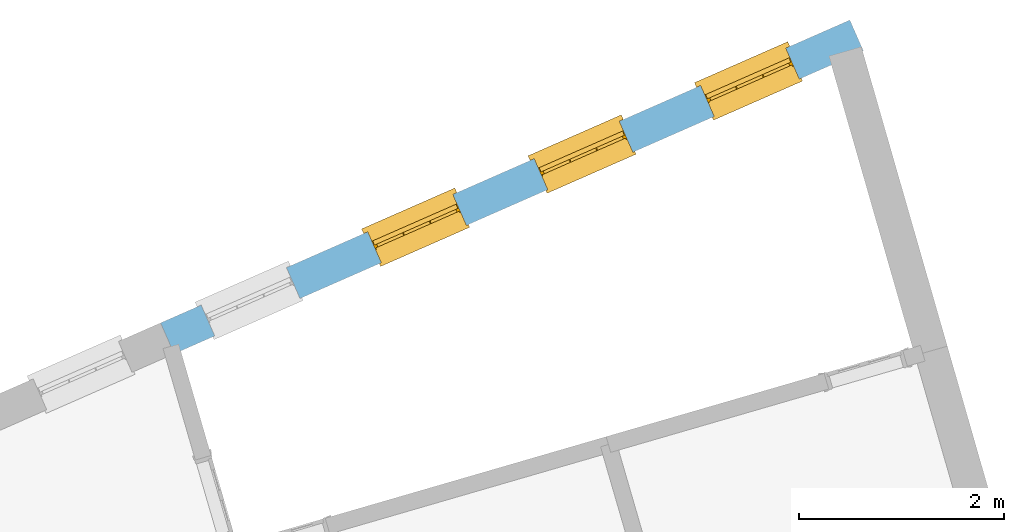
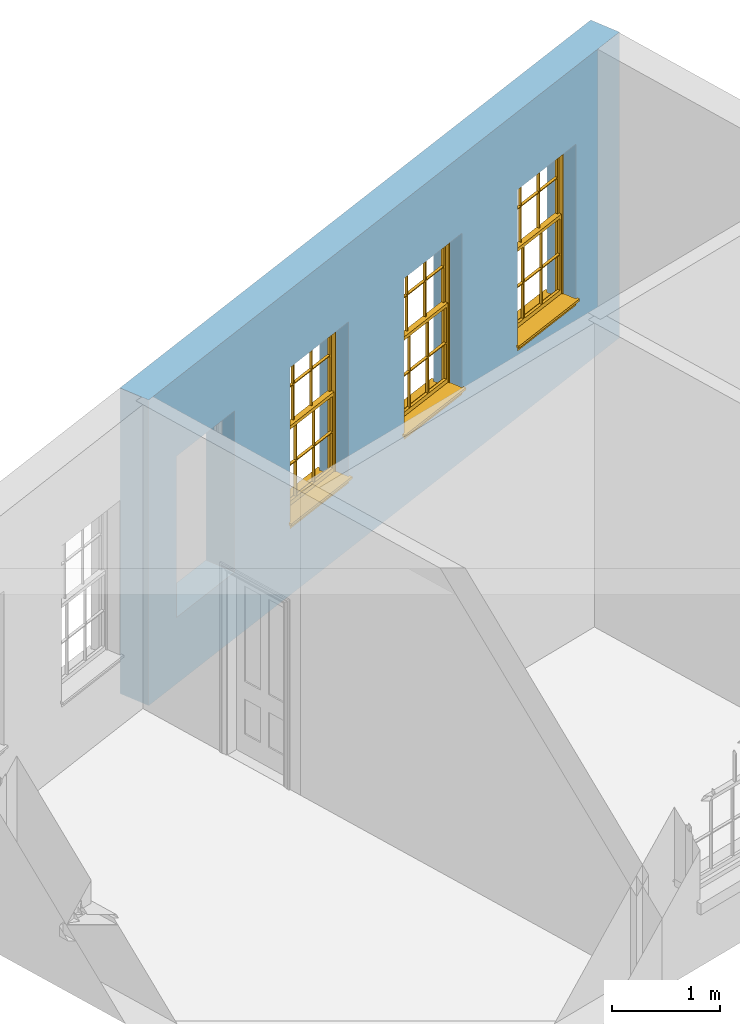
# One storey, part 8 of 11: 3 windows, 4 openings, plus 1 element that does not belong to this part.
"""IFC2X3 building model written with IfcOpenShell, lengths in metres."""

from ifc_helpers import new_model, si_unit, frame, origin, place, context, subcontext, project, spatial, polyline, outline, extrude, faceted_brep, material, layer, layer_set, layer_usage, element, fill, save


model = new_model("IFC2X3")

# Units and contexts
model_context = context("Model", 3, world=origin())
body_context = subcontext(model_context, "Body", "Model", "MODEL_VIEW")
ifc_project = project(units=[si_unit("PLANEANGLEUNIT", "RADIAN"), si_unit("MASSUNIT", "GRAM", prefix="KILO"), si_unit("FORCEUNIT", "NEWTON", prefix="KILO"), si_unit("LENGTHUNIT", "METRE")], contexts=[model_context])

# Site, building, storey
site_placement = place(None, origin())
site = spatial("IfcSite", under=ifc_project, at=site_placement, CompositionType="ELEMENT")
building_placement = place(None, origin())
building = spatial("IfcBuilding", under=site, at=building_placement, Name="Building plot-15", CompositionType="ELEMENT")
storey_placement = place(None, frame((0.0, 0.0, 7.6)))
storey = spatial("IfcBuildingStorey", under=building, at=storey_placement, Name="Floor 1", CompositionType="ELEMENT", Elevation=7.6)

# Wall, openings, windows
ifc_material = material(Name="Masonry")
ifc_layer = layer(ifc_material, 0.33, ventilated=False)
ifc_layer_set = layer_set([ifc_layer], Name="My Wall")
ifc_layer_usage = layer_usage(ifc_layer_set, "AXIS2", "NEGATIVE", 0.08)
wall_placement = place(storey_placement, origin())
wall = element("IfcWallStandardCase", 1, at=wall_placement, inside=storey, material=ifc_layer_usage, Name="exterior", context=body_context, shape_type="SweptSolid", body=[
    extrude(outline(polyline([(95.6723187451732, 60.4106615143609), (95.5395561949644, 60.7127775603797), (88.804220166514, 57.7529864488727), (88.9369827167228, 57.4508704028539), (95.6723187451732, 60.4106615143609)])), origin(), (0.0, 0.0, 1.0), 3.45),
])
opening_1_placement = place(storey_placement, frame((0.0, 0.0, 0.75)))
opening_1 = element("IfcOpeningElement", 2, at=opening_1_placement, cuts=wall, Name="Opening", ObjectType="Opening", context=body_context, shape_type="SweptSolid", body=[
    extrude(outline(polyline([(94.9139268152625, 60.4378495880681), (94.0808189307863, 60.0717467980984), (94.2135814809951, 59.7696307520796), (95.0466893654713, 60.1357335420493), (94.9139268152625, 60.4378495880681)])), origin(), (0.0, 0.0, 1.0), 1.82),
])
opening_2_placement = place(storey_placement, frame((0.0, 0.0, 0.75)))
opening_2 = element("IfcOpeningElement", 3, at=opening_2_placement, cuts=wall, Name="Opening", ObjectType="Opening", context=body_context, shape_type="SweptSolid", body=[
    extrude(outline(polyline([(93.2873117562595, 59.7230462325794), (92.4542038717833, 59.3569434426097), (92.5869664219921, 59.0548273965908), (93.4200743064683, 59.4209301865605), (93.2873117562595, 59.7230462325794)])), origin(), (0.0, 0.0, 1.0), 1.82),
])
opening_3_placement = place(storey_placement, frame((0.0, 0.0, 0.75)))
opening_3 = element("IfcOpeningElement", 4, at=opening_3_placement, cuts=wall, Name="Opening", ObjectType="Opening", context=body_context, shape_type="SweptSolid", body=[
    extrude(outline(polyline([(91.6606966972566, 59.0082428770907), (90.8275888127803, 58.642140087121), (90.9603513629891, 58.3400240411021), (91.7934592474653, 58.7061268310718), (91.6606966972566, 59.0082428770907)])), origin(), (0.0, 0.0, 1.0), 1.82),
])
opening_4_placement = place(storey_placement, frame((0.0, 0.0, 0.75)))
element("IfcOpeningElement", 5, at=opening_4_placement, cuts=wall, Name="Opening", ObjectType="Opening", context=body_context, shape_type="SweptSolid", body=[
    extrude(outline(polyline([(90.0340816382536, 58.2934395216019), (89.2009737537774, 57.9273367316322), (89.3337363039862, 57.6252206856134), (90.1668441884623, 57.9913234755831), (90.0340816382536, 58.2934395216019)])), origin(), (0.0, 0.0, 1.0), 1.82),
])
window_1_placement = place(storey_placement, frame((95.0145045048146, 60.2089737956296, 0.75), z_axis=(0.0, 0.0, 1.0), x_axis=(-0.833107884476192, -0.366102789969688, 0.0)))
window_1 = element("IfcWindow", 6, at=window_1_placement, inside=storey, Name="circulation outside window", OverallHeight=1.82, OverallWidth=0.91, context=body_context, shape_type="Brep", held_by="IfcProductRepresentation", body=[
    faceted_brep([(0.033125, -0.105, 0.975209), (0.01, -0.105, 0.975209), (0.033125, -0.105, 1.376042), (0.876875, -0.105, 0.975209), (0.876875, -0.105, 1.376042), (0.9, -0.105, 0.975209), (0.876875, -0.105, 1.386042), (0.876875, -0.105, 1.786875), (0.9, -0.105, 1.81), (0.033125, -0.105, 1.786875), (0.033125, -0.105, 1.386042), (0.01, -0.105, 1.81), (0.876875, -0.135, 1.376042), (0.876875, -0.135, 0.975209), (0.9, -0.135, 0.937083), (0.033125, -0.135, 1.786875), (0.01, -0.135, 1.81), (0.033125, -0.135, 1.386042), (0.01, -0.135, 0.937083), (0.033125, -0.135, 0.975209), (0.033125, -0.135, 1.376042), (0.876875, -0.135, 1.786875), (0.876875, -0.135, 1.386042), (0.9, -0.135, 1.81), (0.033125, -0.105, 0.937083), (0.01, -0.105, 0.937083), (0.033125, -0.105, 0.53625), (0.876875, -0.105, 0.937083), (0.876875, -0.105, 0.53625), (0.9, -0.105, 0.937083), (0.876875, -0.105, 0.52625), (0.876875, -0.105, 0.125417), (0.9, -0.105, 0.077167), (0.033125, -0.105, 0.125417), (0.033125, -0.105, 0.52625), (0.01, -0.105, 0.077167), (-0.0425, -0.25, 0.01), (-0.0425, -0.3, 0.001667), (0.0, -0.25, 0.01), (0.9525, -0.25, 0.01), (0.91, -0.25, 0.01), (0.9525, -0.3, 0.001667), (-0.02, 0.08, 0.077167), (0.0, 0.08, 0.077167), (-0.02, 0.11, 0.077167), (0.0, -0.06, 0.077167), (0.01, -0.06, 0.077167), (0.91, -0.06, 0.077167), (0.91, 0.08, 0.077167), (0.9, -0.06, 0.077167), (0.93, 0.08, 0.077167), (0.93, 0.11, 0.077167), (0.01, -0.075, 0.975209), (0.9, -0.075, 0.975209), (0.876875, -0.075, 0.125417), (0.876875, -0.075, 0.52625), (0.9, -0.075, 0.077167), (0.876875, -0.075, 0.53625), (0.876875, -0.075, 0.937083), (0.033125, -0.075, 0.125417), (0.01, -0.075, 0.077167), (0.033125, -0.075, 0.52625), (0.033125, -0.075, 0.937083), (0.033125, -0.075, 0.53625), (-0.02, 0.08, 0.052167), (-0.02, 0.11, 0.052167), (0.93, 0.11, 0.052167), (0.93, 0.08, 0.052167), (0.91, 0.08, 0.052167), (0.0, 0.08, 0.052167), (0.91, -0.15, 0.026667), (0.0, -0.15, 0.026667), (-0.0425, -0.3, -0.123333), (0.9525, -0.3, -0.123333), (-0.0425, -0.25, -0.123333), (0.9525, -0.25, -0.123333), (0.01, -0.06, 1.81), (0.9, -0.06, 1.81), (0.0, -0.06, 1.82), (0.91, -0.06, 1.82), (0.01, -0.15, 0.077167), (0.9, -0.15, 0.077167), (0.592292, -0.105, 0.125417), (0.592292, -0.075, 0.125417), (0.317708, -0.075, 0.125417), (0.317708, -0.105, 0.125417), (0.592292, -0.105, 0.53625), (0.317708, -0.105, 0.53625), (0.317708, -0.105, 0.52625), (0.592292, -0.105, 0.52625), (0.592292, -0.075, 0.53625), (0.317708, -0.075, 0.53625), (0.592292, -0.135, 1.386042), (0.592292, -0.105, 1.386042), (0.317708, -0.105, 1.386042), (0.317708, -0.135, 1.386042), (0.317708, -0.135, 1.376042), (0.592292, -0.135, 1.376042), (0.317708, -0.105, 1.376042), (0.592292, -0.105, 1.376042), (0.602292, -0.135, 1.376042), (0.592292, -0.135, 0.975209), (0.602292, -0.135, 0.975209), (0.602292, -0.105, 0.975209), (0.592292, -0.105, 0.975209), (0.602292, -0.105, 1.376042), (0.602292, -0.075, 0.53625), (0.602292, -0.105, 0.53625), (0.317708, -0.075, 0.52625), (0.307708, -0.075, 0.125417), (0.307708, -0.075, 0.52625), (0.602292, -0.075, 0.52625), (0.602292, -0.075, 0.125417), (0.592292, -0.075, 0.52625), (0.307708, -0.075, 0.53625), (0.317708, -0.075, 0.937083), (0.307708, -0.075, 0.937083), (0.602292, -0.075, 0.937083), (0.592292, -0.075, 0.937083), (0.307708, -0.105, 0.52625), (0.307708, -0.105, 0.125417), (0.307708, -0.105, 0.53625), (0.307708, -0.105, 0.937083), (0.592292, -0.105, 0.937083), (0.317708, -0.105, 0.937083), (0.602292, -0.105, 0.937083), (0.602292, -0.105, 0.52625), (0.602292, -0.105, 0.125417), (0.307708, -0.135, 1.386042), (0.307708, -0.135, 1.376042), (0.307708, -0.135, 0.975209), (0.317708, -0.135, 0.975209), (0.317708, -0.135, 1.786875), (0.307708, -0.135, 1.786875), (0.602292, -0.135, 1.786875), (0.592292, -0.135, 1.786875), (0.602292, -0.135, 1.386042), (0.602292, -0.105, 1.386042), (0.307708, -0.105, 1.386042), (0.307708, -0.105, 1.786875), (0.317708, -0.105, 1.786875), (0.592292, -0.105, 1.786875), (0.602292, -0.105, 1.786875), (0.307708, -0.105, 1.376042), (0.317708, -0.105, 0.975209), (0.307708, -0.105, 0.975209), (0.91, -0.15, 1.82), (0.9, -0.15, 1.81), (0.01, -0.15, 1.81), (0.0, -0.15, 1.82), (0.91, -0.25, 0.0), (0.0, -0.25, 0.0), (0.91, 0.08, 0.0), (0.0, 0.08, 0.0)], [[[0, 1, 2]], [[3, 4, 5]], [[6, 7, 8]], [[9, 10, 11]], [[12, 13, 14]], [[15, 16, 17]], [[18, 19, 20]], [[21, 22, 23]], [[24, 25, 26]], [[27, 28, 29]], [[30, 31, 32]], [[33, 34, 35]], [[14, 27, 29]], [[25, 24, 18]], [[36, 37, 38]], [[39, 40, 41]], [[42, 43, 44]], [[45, 46, 43]], [[47, 48, 49]], [[50, 51, 48]], [[1, 0, 52]], [[5, 53, 3]], [[54, 55, 56]], [[57, 58, 53]], [[59, 60, 61]], [[62, 63, 52]], [[48, 43, 46, 49]], [[51, 44, 43, 48]], [[64, 42, 44, 65]], [[65, 44, 51, 66]], [[66, 51, 50, 67]], [[65, 66, 68, 69]], [[60, 56, 49, 46]], [[70, 71, 38, 40]], [[37, 41, 40, 38]], [[37, 72, 73, 41]], [[74, 75, 73, 72]], [[8, 11, 76, 77]], [[76, 78, 79, 77]], [[32, 35, 80, 81]], [[81, 80, 71, 70]], [[82, 83, 84, 85]], [[86, 87, 88, 89]], [[86, 90, 91, 87]], [[92, 93, 94, 95]], [[92, 95, 96, 97]], [[96, 98, 99, 97]], [[100, 97, 101, 102]], [[103, 104, 99, 105]], [[97, 99, 104, 101]], [[102, 103, 105, 100]], [[28, 57, 106, 107]], [[108, 84, 109, 110]], [[111, 112, 83, 113]], [[114, 110, 61, 63]], [[90, 113, 108, 91]], [[115, 91, 114, 116]], [[117, 106, 90, 118]], [[111, 106, 57, 55]], [[119, 110, 109, 120]], [[34, 61, 110, 119]], [[89, 113, 83, 82]], [[88, 108, 113, 89]], [[85, 84, 108, 88]], [[121, 114, 63, 26]], [[122, 116, 114, 121]], [[123, 118, 90, 86]], [[87, 91, 115, 124]], [[107, 106, 117, 125]], [[126, 111, 55, 30]], [[127, 112, 111, 126]], [[126, 30, 28, 107]], [[88, 119, 120, 85]], [[126, 89, 82, 127]], [[125, 123, 86, 107]], [[121, 26, 34, 119]], [[124, 122, 121, 87]], [[128, 17, 20, 129]], [[96, 129, 130, 131]], [[132, 133, 128, 95]], [[134, 135, 92, 136]], [[100, 12, 22, 136]], [[137, 6, 4, 105]], [[94, 138, 139, 140]], [[137, 93, 141, 142]], [[99, 98, 94, 93]], [[143, 2, 10, 138]], [[144, 145, 143, 98]], [[129, 143, 145, 130]], [[20, 2, 143, 129]], [[131, 144, 98, 96]], [[128, 138, 10, 17]], [[133, 139, 138, 128]], [[135, 141, 93, 92]], [[95, 94, 140, 132]], [[22, 6, 137, 136]], [[136, 137, 142, 134]], [[100, 105, 4, 12]], [[107, 86, 89, 126]], [[106, 111, 113, 90]], [[91, 108, 110, 114]], [[87, 121, 119, 88]], [[97, 100, 136, 92]], [[129, 96, 95, 128]], [[98, 143, 138, 94]], [[105, 99, 93, 137]], [[131, 101, 104, 144]], [[124, 115, 118, 123]], [[132, 140, 141, 135]], [[120, 109, 59, 33]], [[15, 9, 139, 133]], [[134, 142, 7, 21]], [[31, 54, 112, 127]], [[36, 74, 72, 37]], [[39, 41, 73, 75]], [[18, 14, 101, 131]], [[23, 16, 132, 135]], [[83, 56, 60, 84]], [[52, 53, 118, 115]], [[53, 52, 144, 104]], [[11, 8, 141, 140]], [[14, 18, 124, 123]], [[2, 1, 11, 10]], [[8, 5, 4, 6]], [[57, 53, 56, 55]], [[60, 52, 63, 61]], [[26, 25, 35, 34]], [[32, 29, 28, 30]], [[14, 23, 22, 12]], [[18, 20, 17, 16]], [[19, 0, 2, 20]], [[17, 10, 9, 15]], [[12, 4, 3, 13]], [[21, 7, 6, 22]], [[27, 58, 57, 28]], [[30, 55, 54, 31]], [[33, 59, 61, 34]], [[26, 63, 62, 24]], [[5, 8, 77, 53]], [[76, 11, 1, 52]], [[46, 45, 78, 76]], [[49, 77, 79, 47]], [[70, 146, 147, 81]], [[71, 80, 148, 149]], [[19, 130, 145, 0]], [[102, 13, 3, 103]], [[116, 122, 24, 62]], [[29, 32, 81, 14]], [[80, 35, 25, 18]], [[60, 46, 76, 52]], [[77, 49, 56, 53]], [[23, 14, 81, 147]], [[16, 148, 80, 18]], [[35, 85, 120]], [[120, 33, 35]], [[127, 82, 32]], [[32, 31, 127]], [[32, 82, 85, 35]], [[102, 101, 14]], [[14, 13, 102]], [[18, 131, 130]], [[130, 19, 18]], [[134, 21, 23]], [[23, 135, 134]], [[16, 15, 133]], [[133, 132, 16]], [[11, 140, 139]], [[139, 9, 11]], [[142, 141, 8]], [[8, 7, 142]], [[23, 147, 148, 16]], [[146, 149, 148, 147]], [[52, 115, 116]], [[116, 62, 52]], [[118, 53, 117]], [[58, 117, 53]], [[27, 125, 117, 58]], [[56, 83, 112]], [[112, 54, 56]], [[109, 84, 60]], [[60, 59, 109]], [[125, 27, 14]], [[14, 123, 125]], [[122, 124, 18]], [[18, 24, 122]], [[145, 144, 52]], [[52, 0, 145]], [[103, 3, 53]], [[53, 104, 103]], [[79, 78, 149, 146]], [[78, 45, 71, 149]], [[146, 70, 47, 79]], [[150, 75, 74, 151]], [[68, 66, 67]], [[48, 68, 67, 50]], [[69, 64, 65]], [[42, 64, 69, 43]], [[69, 68, 152, 153]], [[70, 68, 48, 47]], [[150, 152, 68, 70]], [[43, 69, 71, 45]], [[69, 153, 151, 71]], [[152, 150, 151, 153]], [[38, 151, 74, 36]], [[71, 151, 38]], [[39, 75, 150, 40]], [[40, 150, 70]]]),
])
fill(opening_1, window_1)
window_2_placement = place(storey_placement, frame((93.3878894458116, 59.4941704401409, 0.75), z_axis=(0.0, 0.0, 1.0), x_axis=(-0.833107884476206, -0.366102789969695, 0.0)))
window_2 = element("IfcWindow", 7, at=window_2_placement, inside=storey, Name="circulation outside window", OverallHeight=1.82, OverallWidth=0.91, context=body_context, shape_type="Brep", held_by="IfcProductRepresentation", body=[
    faceted_brep([(0.033125, -0.105, 0.975209), (0.01, -0.105, 0.975209), (0.033125, -0.105, 1.376042), (0.876875, -0.105, 0.975209), (0.876875, -0.105, 1.376042), (0.9, -0.105, 0.975209), (0.876875, -0.105, 1.386042), (0.876875, -0.105, 1.786875), (0.9, -0.105, 1.81), (0.033125, -0.105, 1.786875), (0.033125, -0.105, 1.386042), (0.01, -0.105, 1.81), (0.876875, -0.135, 1.376042), (0.876875, -0.135, 0.975209), (0.9, -0.135, 0.937083), (0.033125, -0.135, 1.786875), (0.01, -0.135, 1.81), (0.033125, -0.135, 1.386042), (0.01, -0.135, 0.937083), (0.033125, -0.135, 0.975209), (0.033125, -0.135, 1.376042), (0.876875, -0.135, 1.786875), (0.876875, -0.135, 1.386042), (0.9, -0.135, 1.81), (0.033125, -0.105, 0.937083), (0.01, -0.105, 0.937083), (0.033125, -0.105, 0.53625), (0.876875, -0.105, 0.937083), (0.876875, -0.105, 0.53625), (0.9, -0.105, 0.937083), (0.876875, -0.105, 0.52625), (0.876875, -0.105, 0.125417), (0.9, -0.105, 0.077167), (0.033125, -0.105, 0.125417), (0.033125, -0.105, 0.52625), (0.01, -0.105, 0.077167), (-0.0425, -0.25, 0.01), (-0.0425, -0.3, 0.001667), (0.0, -0.25, 0.01), (0.9525, -0.25, 0.01), (0.91, -0.25, 0.01), (0.9525, -0.3, 0.001667), (-0.02, 0.08, 0.077167), (0.0, 0.08, 0.077167), (-0.02, 0.11, 0.077167), (0.0, -0.06, 0.077167), (0.01, -0.06, 0.077167), (0.91, -0.06, 0.077167), (0.91, 0.08, 0.077167), (0.9, -0.06, 0.077167), (0.93, 0.08, 0.077167), (0.93, 0.11, 0.077167), (0.01, -0.075, 0.975209), (0.9, -0.075, 0.975209), (0.876875, -0.075, 0.125417), (0.876875, -0.075, 0.52625), (0.9, -0.075, 0.077167), (0.876875, -0.075, 0.53625), (0.876875, -0.075, 0.937083), (0.033125, -0.075, 0.125417), (0.01, -0.075, 0.077167), (0.033125, -0.075, 0.52625), (0.033125, -0.075, 0.937083), (0.033125, -0.075, 0.53625), (-0.02, 0.08, 0.052167), (-0.02, 0.11, 0.052167), (0.93, 0.11, 0.052167), (0.93, 0.08, 0.052167), (0.91, 0.08, 0.052167), (0.0, 0.08, 0.052167), (0.91, -0.15, 0.026667), (0.0, -0.15, 0.026667), (-0.0425, -0.3, -0.123333), (0.9525, -0.3, -0.123333), (-0.0425, -0.25, -0.123333), (0.9525, -0.25, -0.123333), (0.01, -0.06, 1.81), (0.9, -0.06, 1.81), (0.0, -0.06, 1.82), (0.91, -0.06, 1.82), (0.01, -0.15, 0.077167), (0.9, -0.15, 0.077167), (0.592292, -0.105, 0.125417), (0.592292, -0.075, 0.125417), (0.317708, -0.075, 0.125417), (0.317708, -0.105, 0.125417), (0.592292, -0.105, 0.53625), (0.317708, -0.105, 0.53625), (0.317708, -0.105, 0.52625), (0.592292, -0.105, 0.52625), (0.592292, -0.075, 0.53625), (0.317708, -0.075, 0.53625), (0.592292, -0.135, 1.386042), (0.592292, -0.105, 1.386042), (0.317708, -0.105, 1.386042), (0.317708, -0.135, 1.386042), (0.317708, -0.135, 1.376042), (0.592292, -0.135, 1.376042), (0.317708, -0.105, 1.376042), (0.592292, -0.105, 1.376042), (0.602292, -0.135, 1.376042), (0.592292, -0.135, 0.975209), (0.602292, -0.135, 0.975209), (0.602292, -0.105, 0.975209), (0.592292, -0.105, 0.975209), (0.602292, -0.105, 1.376042), (0.602292, -0.075, 0.53625), (0.602292, -0.105, 0.53625), (0.317708, -0.075, 0.52625), (0.307708, -0.075, 0.125417), (0.307708, -0.075, 0.52625), (0.602292, -0.075, 0.52625), (0.602292, -0.075, 0.125417), (0.592292, -0.075, 0.52625), (0.307708, -0.075, 0.53625), (0.317708, -0.075, 0.937083), (0.307708, -0.075, 0.937083), (0.602292, -0.075, 0.937083), (0.592292, -0.075, 0.937083), (0.307708, -0.105, 0.52625), (0.307708, -0.105, 0.125417), (0.307708, -0.105, 0.53625), (0.307708, -0.105, 0.937083), (0.592292, -0.105, 0.937083), (0.317708, -0.105, 0.937083), (0.602292, -0.105, 0.937083), (0.602292, -0.105, 0.52625), (0.602292, -0.105, 0.125417), (0.307708, -0.135, 1.386042), (0.307708, -0.135, 1.376042), (0.307708, -0.135, 0.975209), (0.317708, -0.135, 0.975209), (0.317708, -0.135, 1.786875), (0.307708, -0.135, 1.786875), (0.602292, -0.135, 1.786875), (0.592292, -0.135, 1.786875), (0.602292, -0.135, 1.386042), (0.602292, -0.105, 1.386042), (0.307708, -0.105, 1.386042), (0.307708, -0.105, 1.786875), (0.317708, -0.105, 1.786875), (0.592292, -0.105, 1.786875), (0.602292, -0.105, 1.786875), (0.307708, -0.105, 1.376042), (0.317708, -0.105, 0.975209), (0.307708, -0.105, 0.975209), (0.91, -0.15, 1.82), (0.9, -0.15, 1.81), (0.01, -0.15, 1.81), (0.0, -0.15, 1.82), (0.91, -0.25, 0.0), (0.0, -0.25, 0.0), (0.91, 0.08, 0.0), (0.0, 0.08, 0.0)], [[[0, 1, 2]], [[3, 4, 5]], [[6, 7, 8]], [[9, 10, 11]], [[12, 13, 14]], [[15, 16, 17]], [[18, 19, 20]], [[21, 22, 23]], [[24, 25, 26]], [[27, 28, 29]], [[30, 31, 32]], [[33, 34, 35]], [[14, 27, 29]], [[25, 24, 18]], [[36, 37, 38]], [[39, 40, 41]], [[42, 43, 44]], [[45, 46, 43]], [[47, 48, 49]], [[50, 51, 48]], [[1, 0, 52]], [[5, 53, 3]], [[54, 55, 56]], [[57, 58, 53]], [[59, 60, 61]], [[62, 63, 52]], [[48, 43, 46, 49]], [[51, 44, 43, 48]], [[64, 42, 44, 65]], [[65, 44, 51, 66]], [[66, 51, 50, 67]], [[65, 66, 68, 69]], [[60, 56, 49, 46]], [[70, 71, 38, 40]], [[37, 41, 40, 38]], [[37, 72, 73, 41]], [[74, 75, 73, 72]], [[8, 11, 76, 77]], [[76, 78, 79, 77]], [[32, 35, 80, 81]], [[81, 80, 71, 70]], [[82, 83, 84, 85]], [[86, 87, 88, 89]], [[86, 90, 91, 87]], [[92, 93, 94, 95]], [[92, 95, 96, 97]], [[96, 98, 99, 97]], [[100, 97, 101, 102]], [[103, 104, 99, 105]], [[97, 99, 104, 101]], [[102, 103, 105, 100]], [[28, 57, 106, 107]], [[108, 84, 109, 110]], [[111, 112, 83, 113]], [[114, 110, 61, 63]], [[90, 113, 108, 91]], [[115, 91, 114, 116]], [[117, 106, 90, 118]], [[111, 106, 57, 55]], [[119, 110, 109, 120]], [[34, 61, 110, 119]], [[89, 113, 83, 82]], [[88, 108, 113, 89]], [[85, 84, 108, 88]], [[121, 114, 63, 26]], [[122, 116, 114, 121]], [[123, 118, 90, 86]], [[87, 91, 115, 124]], [[107, 106, 117, 125]], [[126, 111, 55, 30]], [[127, 112, 111, 126]], [[126, 30, 28, 107]], [[88, 119, 120, 85]], [[126, 89, 82, 127]], [[125, 123, 86, 107]], [[121, 26, 34, 119]], [[124, 122, 121, 87]], [[128, 17, 20, 129]], [[96, 129, 130, 131]], [[132, 133, 128, 95]], [[134, 135, 92, 136]], [[100, 12, 22, 136]], [[137, 6, 4, 105]], [[94, 138, 139, 140]], [[137, 93, 141, 142]], [[99, 98, 94, 93]], [[143, 2, 10, 138]], [[144, 145, 143, 98]], [[129, 143, 145, 130]], [[20, 2, 143, 129]], [[131, 144, 98, 96]], [[128, 138, 10, 17]], [[133, 139, 138, 128]], [[135, 141, 93, 92]], [[95, 94, 140, 132]], [[22, 6, 137, 136]], [[136, 137, 142, 134]], [[100, 105, 4, 12]], [[107, 86, 89, 126]], [[106, 111, 113, 90]], [[91, 108, 110, 114]], [[87, 121, 119, 88]], [[97, 100, 136, 92]], [[129, 96, 95, 128]], [[98, 143, 138, 94]], [[105, 99, 93, 137]], [[131, 101, 104, 144]], [[124, 115, 118, 123]], [[132, 140, 141, 135]], [[120, 109, 59, 33]], [[15, 9, 139, 133]], [[134, 142, 7, 21]], [[31, 54, 112, 127]], [[36, 74, 72, 37]], [[39, 41, 73, 75]], [[18, 14, 101, 131]], [[23, 16, 132, 135]], [[83, 56, 60, 84]], [[52, 53, 118, 115]], [[53, 52, 144, 104]], [[11, 8, 141, 140]], [[14, 18, 124, 123]], [[2, 1, 11, 10]], [[8, 5, 4, 6]], [[57, 53, 56, 55]], [[60, 52, 63, 61]], [[26, 25, 35, 34]], [[32, 29, 28, 30]], [[14, 23, 22, 12]], [[18, 20, 17, 16]], [[19, 0, 2, 20]], [[17, 10, 9, 15]], [[12, 4, 3, 13]], [[21, 7, 6, 22]], [[27, 58, 57, 28]], [[30, 55, 54, 31]], [[33, 59, 61, 34]], [[26, 63, 62, 24]], [[5, 8, 77, 53]], [[76, 11, 1, 52]], [[46, 45, 78, 76]], [[49, 77, 79, 47]], [[70, 146, 147, 81]], [[71, 80, 148, 149]], [[19, 130, 145, 0]], [[102, 13, 3, 103]], [[116, 122, 24, 62]], [[29, 32, 81, 14]], [[80, 35, 25, 18]], [[60, 46, 76, 52]], [[77, 49, 56, 53]], [[23, 14, 81, 147]], [[16, 148, 80, 18]], [[35, 85, 120]], [[120, 33, 35]], [[127, 82, 32]], [[32, 31, 127]], [[32, 82, 85, 35]], [[102, 101, 14]], [[14, 13, 102]], [[18, 131, 130]], [[130, 19, 18]], [[134, 21, 23]], [[23, 135, 134]], [[16, 15, 133]], [[133, 132, 16]], [[11, 140, 139]], [[139, 9, 11]], [[142, 141, 8]], [[8, 7, 142]], [[23, 147, 148, 16]], [[146, 149, 148, 147]], [[52, 115, 116]], [[116, 62, 52]], [[118, 53, 117]], [[58, 117, 53]], [[27, 125, 117, 58]], [[56, 83, 112]], [[112, 54, 56]], [[109, 84, 60]], [[60, 59, 109]], [[125, 27, 14]], [[14, 123, 125]], [[122, 124, 18]], [[18, 24, 122]], [[145, 144, 52]], [[52, 0, 145]], [[103, 3, 53]], [[53, 104, 103]], [[79, 78, 149, 146]], [[78, 45, 71, 149]], [[146, 70, 47, 79]], [[150, 75, 74, 151]], [[68, 66, 67]], [[48, 68, 67, 50]], [[69, 64, 65]], [[42, 64, 69, 43]], [[69, 68, 152, 153]], [[70, 68, 48, 47]], [[150, 152, 68, 70]], [[43, 69, 71, 45]], [[69, 153, 151, 71]], [[152, 150, 151, 153]], [[38, 151, 74, 36]], [[71, 151, 38]], [[39, 75, 150, 40]], [[40, 150, 70]]]),
])
fill(opening_2, window_2)
window_3_placement = place(storey_placement, frame((91.7612743868087, 58.7793670846521, 0.75), z_axis=(0.0, 0.0, 1.0), x_axis=(-0.833107884476206, -0.366102789969695, 0.0)))
window_3 = element("IfcWindow", 8, at=window_3_placement, inside=storey, Name="circulation outside window", OverallHeight=1.82, OverallWidth=0.91, context=body_context, shape_type="Brep", held_by="IfcProductRepresentation", body=[
    faceted_brep([(0.033125, -0.105, 0.975209), (0.01, -0.105, 0.975209), (0.033125, -0.105, 1.376042), (0.876875, -0.105, 0.975209), (0.876875, -0.105, 1.376042), (0.9, -0.105, 0.975209), (0.876875, -0.105, 1.386042), (0.876875, -0.105, 1.786875), (0.9, -0.105, 1.81), (0.033125, -0.105, 1.786875), (0.033125, -0.105, 1.386042), (0.01, -0.105, 1.81), (0.876875, -0.135, 1.376042), (0.876875, -0.135, 0.975209), (0.9, -0.135, 0.937083), (0.033125, -0.135, 1.786875), (0.01, -0.135, 1.81), (0.033125, -0.135, 1.386042), (0.01, -0.135, 0.937083), (0.033125, -0.135, 0.975209), (0.033125, -0.135, 1.376042), (0.876875, -0.135, 1.786875), (0.876875, -0.135, 1.386042), (0.9, -0.135, 1.81), (0.033125, -0.105, 0.937083), (0.01, -0.105, 0.937083), (0.033125, -0.105, 0.53625), (0.876875, -0.105, 0.937083), (0.876875, -0.105, 0.53625), (0.9, -0.105, 0.937083), (0.876875, -0.105, 0.52625), (0.876875, -0.105, 0.125417), (0.9, -0.105, 0.077167), (0.033125, -0.105, 0.125417), (0.033125, -0.105, 0.52625), (0.01, -0.105, 0.077167), (-0.0425, -0.25, 0.01), (-0.0425, -0.3, 0.001667), (0.0, -0.25, 0.01), (0.9525, -0.25, 0.01), (0.91, -0.25, 0.01), (0.9525, -0.3, 0.001667), (-0.02, 0.08, 0.077167), (0.0, 0.08, 0.077167), (-0.02, 0.11, 0.077167), (0.0, -0.06, 0.077167), (0.01, -0.06, 0.077167), (0.91, -0.06, 0.077167), (0.91, 0.08, 0.077167), (0.9, -0.06, 0.077167), (0.93, 0.08, 0.077167), (0.93, 0.11, 0.077167), (0.01, -0.075, 0.975209), (0.9, -0.075, 0.975209), (0.876875, -0.075, 0.125417), (0.876875, -0.075, 0.52625), (0.9, -0.075, 0.077167), (0.876875, -0.075, 0.53625), (0.876875, -0.075, 0.937083), (0.033125, -0.075, 0.125417), (0.01, -0.075, 0.077167), (0.033125, -0.075, 0.52625), (0.033125, -0.075, 0.937083), (0.033125, -0.075, 0.53625), (-0.02, 0.08, 0.052167), (-0.02, 0.11, 0.052167), (0.93, 0.11, 0.052167), (0.93, 0.08, 0.052167), (0.91, 0.08, 0.052167), (0.0, 0.08, 0.052167), (0.91, -0.15, 0.026667), (0.0, -0.15, 0.026667), (-0.0425, -0.3, -0.123333), (0.9525, -0.3, -0.123333), (-0.0425, -0.25, -0.123333), (0.9525, -0.25, -0.123333), (0.01, -0.06, 1.81), (0.9, -0.06, 1.81), (0.0, -0.06, 1.82), (0.91, -0.06, 1.82), (0.01, -0.15, 0.077167), (0.9, -0.15, 0.077167), (0.592292, -0.105, 0.125417), (0.592292, -0.075, 0.125417), (0.317708, -0.075, 0.125417), (0.317708, -0.105, 0.125417), (0.592292, -0.105, 0.53625), (0.317708, -0.105, 0.53625), (0.317708, -0.105, 0.52625), (0.592292, -0.105, 0.52625), (0.592292, -0.075, 0.53625), (0.317708, -0.075, 0.53625), (0.592292, -0.135, 1.386042), (0.592292, -0.105, 1.386042), (0.317708, -0.105, 1.386042), (0.317708, -0.135, 1.386042), (0.317708, -0.135, 1.376042), (0.592292, -0.135, 1.376042), (0.317708, -0.105, 1.376042), (0.592292, -0.105, 1.376042), (0.602292, -0.135, 1.376042), (0.592292, -0.135, 0.975209), (0.602292, -0.135, 0.975209), (0.602292, -0.105, 0.975209), (0.592292, -0.105, 0.975209), (0.602292, -0.105, 1.376042), (0.602292, -0.075, 0.53625), (0.602292, -0.105, 0.53625), (0.317708, -0.075, 0.52625), (0.307708, -0.075, 0.125417), (0.307708, -0.075, 0.52625), (0.602292, -0.075, 0.52625), (0.602292, -0.075, 0.125417), (0.592292, -0.075, 0.52625), (0.307708, -0.075, 0.53625), (0.317708, -0.075, 0.937083), (0.307708, -0.075, 0.937083), (0.602292, -0.075, 0.937083), (0.592292, -0.075, 0.937083), (0.307708, -0.105, 0.52625), (0.307708, -0.105, 0.125417), (0.307708, -0.105, 0.53625), (0.307708, -0.105, 0.937083), (0.592292, -0.105, 0.937083), (0.317708, -0.105, 0.937083), (0.602292, -0.105, 0.937083), (0.602292, -0.105, 0.52625), (0.602292, -0.105, 0.125417), (0.307708, -0.135, 1.386042), (0.307708, -0.135, 1.376042), (0.307708, -0.135, 0.975209), (0.317708, -0.135, 0.975209), (0.317708, -0.135, 1.786875), (0.307708, -0.135, 1.786875), (0.602292, -0.135, 1.786875), (0.592292, -0.135, 1.786875), (0.602292, -0.135, 1.386042), (0.602292, -0.105, 1.386042), (0.307708, -0.105, 1.386042), (0.307708, -0.105, 1.786875), (0.317708, -0.105, 1.786875), (0.592292, -0.105, 1.786875), (0.602292, -0.105, 1.786875), (0.307708, -0.105, 1.376042), (0.317708, -0.105, 0.975209), (0.307708, -0.105, 0.975209), (0.91, -0.15, 1.82), (0.9, -0.15, 1.81), (0.01, -0.15, 1.81), (0.0, -0.15, 1.82), (0.91, -0.25, 0.0), (0.0, -0.25, 0.0), (0.91, 0.08, 0.0), (0.0, 0.08, 0.0)], [[[0, 1, 2]], [[3, 4, 5]], [[6, 7, 8]], [[9, 10, 11]], [[12, 13, 14]], [[15, 16, 17]], [[18, 19, 20]], [[21, 22, 23]], [[24, 25, 26]], [[27, 28, 29]], [[30, 31, 32]], [[33, 34, 35]], [[14, 27, 29]], [[25, 24, 18]], [[36, 37, 38]], [[39, 40, 41]], [[42, 43, 44]], [[45, 46, 43]], [[47, 48, 49]], [[50, 51, 48]], [[1, 0, 52]], [[5, 53, 3]], [[54, 55, 56]], [[57, 58, 53]], [[59, 60, 61]], [[62, 63, 52]], [[48, 43, 46, 49]], [[51, 44, 43, 48]], [[64, 42, 44, 65]], [[65, 44, 51, 66]], [[66, 51, 50, 67]], [[65, 66, 68, 69]], [[60, 56, 49, 46]], [[70, 71, 38, 40]], [[37, 41, 40, 38]], [[37, 72, 73, 41]], [[74, 75, 73, 72]], [[8, 11, 76, 77]], [[76, 78, 79, 77]], [[32, 35, 80, 81]], [[81, 80, 71, 70]], [[82, 83, 84, 85]], [[86, 87, 88, 89]], [[86, 90, 91, 87]], [[92, 93, 94, 95]], [[92, 95, 96, 97]], [[96, 98, 99, 97]], [[100, 97, 101, 102]], [[103, 104, 99, 105]], [[97, 99, 104, 101]], [[102, 103, 105, 100]], [[28, 57, 106, 107]], [[108, 84, 109, 110]], [[111, 112, 83, 113]], [[114, 110, 61, 63]], [[90, 113, 108, 91]], [[115, 91, 114, 116]], [[117, 106, 90, 118]], [[111, 106, 57, 55]], [[119, 110, 109, 120]], [[34, 61, 110, 119]], [[89, 113, 83, 82]], [[88, 108, 113, 89]], [[85, 84, 108, 88]], [[121, 114, 63, 26]], [[122, 116, 114, 121]], [[123, 118, 90, 86]], [[87, 91, 115, 124]], [[107, 106, 117, 125]], [[126, 111, 55, 30]], [[127, 112, 111, 126]], [[126, 30, 28, 107]], [[88, 119, 120, 85]], [[126, 89, 82, 127]], [[125, 123, 86, 107]], [[121, 26, 34, 119]], [[124, 122, 121, 87]], [[128, 17, 20, 129]], [[96, 129, 130, 131]], [[132, 133, 128, 95]], [[134, 135, 92, 136]], [[100, 12, 22, 136]], [[137, 6, 4, 105]], [[94, 138, 139, 140]], [[137, 93, 141, 142]], [[99, 98, 94, 93]], [[143, 2, 10, 138]], [[144, 145, 143, 98]], [[129, 143, 145, 130]], [[20, 2, 143, 129]], [[131, 144, 98, 96]], [[128, 138, 10, 17]], [[133, 139, 138, 128]], [[135, 141, 93, 92]], [[95, 94, 140, 132]], [[22, 6, 137, 136]], [[136, 137, 142, 134]], [[100, 105, 4, 12]], [[107, 86, 89, 126]], [[106, 111, 113, 90]], [[91, 108, 110, 114]], [[87, 121, 119, 88]], [[97, 100, 136, 92]], [[129, 96, 95, 128]], [[98, 143, 138, 94]], [[105, 99, 93, 137]], [[131, 101, 104, 144]], [[124, 115, 118, 123]], [[132, 140, 141, 135]], [[120, 109, 59, 33]], [[15, 9, 139, 133]], [[134, 142, 7, 21]], [[31, 54, 112, 127]], [[36, 74, 72, 37]], [[39, 41, 73, 75]], [[18, 14, 101, 131]], [[23, 16, 132, 135]], [[83, 56, 60, 84]], [[52, 53, 118, 115]], [[53, 52, 144, 104]], [[11, 8, 141, 140]], [[14, 18, 124, 123]], [[2, 1, 11, 10]], [[8, 5, 4, 6]], [[57, 53, 56, 55]], [[60, 52, 63, 61]], [[26, 25, 35, 34]], [[32, 29, 28, 30]], [[14, 23, 22, 12]], [[18, 20, 17, 16]], [[19, 0, 2, 20]], [[17, 10, 9, 15]], [[12, 4, 3, 13]], [[21, 7, 6, 22]], [[27, 58, 57, 28]], [[30, 55, 54, 31]], [[33, 59, 61, 34]], [[26, 63, 62, 24]], [[5, 8, 77, 53]], [[76, 11, 1, 52]], [[46, 45, 78, 76]], [[49, 77, 79, 47]], [[70, 146, 147, 81]], [[71, 80, 148, 149]], [[19, 130, 145, 0]], [[102, 13, 3, 103]], [[116, 122, 24, 62]], [[29, 32, 81, 14]], [[80, 35, 25, 18]], [[60, 46, 76, 52]], [[77, 49, 56, 53]], [[23, 14, 81, 147]], [[16, 148, 80, 18]], [[35, 85, 120]], [[120, 33, 35]], [[127, 82, 32]], [[32, 31, 127]], [[32, 82, 85, 35]], [[102, 101, 14]], [[14, 13, 102]], [[18, 131, 130]], [[130, 19, 18]], [[134, 21, 23]], [[23, 135, 134]], [[16, 15, 133]], [[133, 132, 16]], [[11, 140, 139]], [[139, 9, 11]], [[142, 141, 8]], [[8, 7, 142]], [[23, 147, 148, 16]], [[146, 149, 148, 147]], [[52, 115, 116]], [[116, 62, 52]], [[118, 53, 117]], [[58, 117, 53]], [[27, 125, 117, 58]], [[56, 83, 112]], [[112, 54, 56]], [[109, 84, 60]], [[60, 59, 109]], [[125, 27, 14]], [[14, 123, 125]], [[122, 124, 18]], [[18, 24, 122]], [[145, 144, 52]], [[52, 0, 145]], [[103, 3, 53]], [[53, 104, 103]], [[79, 78, 149, 146]], [[78, 45, 71, 149]], [[146, 70, 47, 79]], [[150, 75, 74, 151]], [[68, 66, 67]], [[48, 68, 67, 50]], [[69, 64, 65]], [[42, 64, 69, 43]], [[69, 68, 152, 153]], [[70, 68, 48, 47]], [[150, 152, 68, 70]], [[43, 69, 71, 45]], [[69, 153, 151, 71]], [[152, 150, 151, 153]], [[38, 151, 74, 36]], [[71, 151, 38]], [[39, 75, 150, 40]], [[40, 150, 70]]]),
])
fill(opening_3, window_3)

save(model, "model.ifc")
